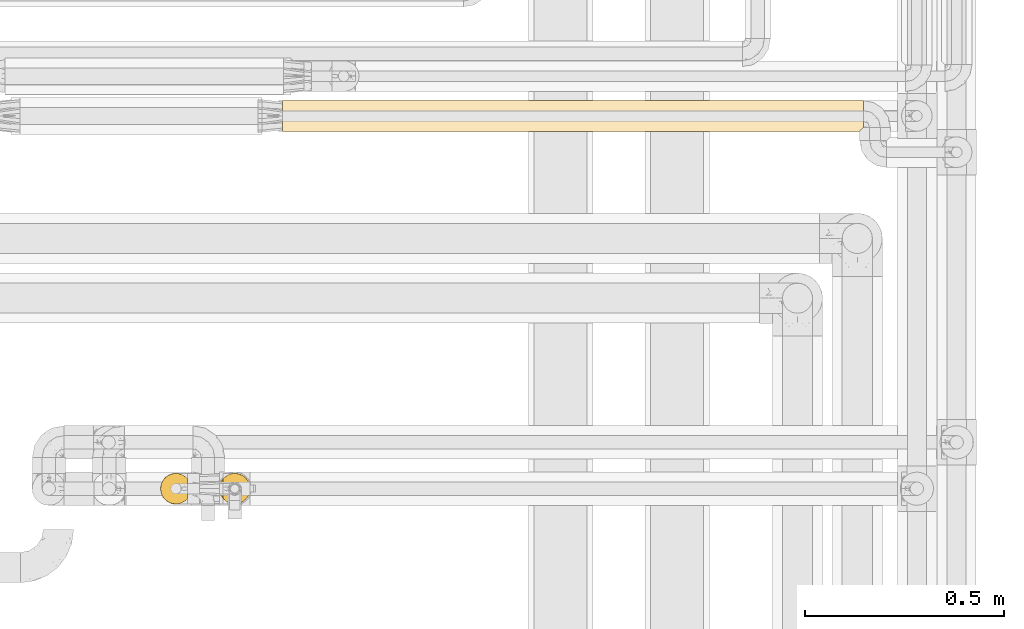
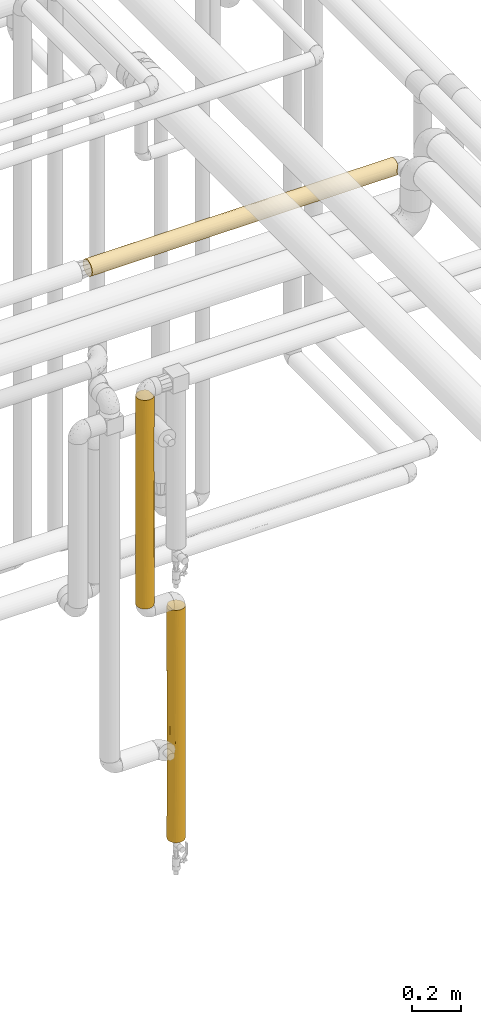
# One storey, part 48 of 827: 3 coverings.
"""IFC2X3 building model written with IfcOpenShell, lengths in millimetres."""

from ifc_helpers import new_model, entity, si_unit, converted_unit, derived_unit, direction, frame, origin, place, context, subcontext, project, spatial, faceted_brep, element, save


model = new_model("IFC2X3")

# Units and contexts
model_context = context("Model", 3, precision=0.01, world=origin(), true_north=direction((6.12303176911189e-17, 1.0)))
body_context = subcontext(model_context, "Body", "Model", "MODEL_VIEW")
ifc_project = project(units=[si_unit("LENGTHUNIT", "METRE", prefix="MILLI"), si_unit("AREAUNIT", "SQUARE_METRE"), si_unit("VOLUMEUNIT", "CUBIC_METRE"), converted_unit("PLANEANGLEUNIT", "DEGREE", entity("IfcRatioMeasure", 0.0174532925199433), si_unit("PLANEANGLEUNIT", "RADIAN"), dimensions=[0, 0, 0, 0, 0, 0, 0]), si_unit("MASSUNIT", "GRAM", prefix="KILO"), derived_unit("MASSDENSITYUNIT", [(si_unit("MASSUNIT", "GRAM", prefix="KILO"), 1), (si_unit("LENGTHUNIT", "METRE"), -3)]), derived_unit("MOMENTOFINERTIAUNIT", [(si_unit("LENGTHUNIT", "METRE"), 4)]), si_unit("TIMEUNIT", "SECOND"), si_unit("FREQUENCYUNIT", "HERTZ"), si_unit("THERMODYNAMICTEMPERATUREUNIT", "DEGREE_CELSIUS"), derived_unit("THERMALTRANSMITTANCEUNIT", [(si_unit("MASSUNIT", "GRAM", prefix="KILO"), 1), (si_unit("THERMODYNAMICTEMPERATUREUNIT", "KELVIN"), -1), (si_unit("TIMEUNIT", "SECOND"), -3)]), derived_unit("VOLUMETRICFLOWRATEUNIT", [(si_unit("LENGTHUNIT", "METRE"), 3), (si_unit("TIMEUNIT", "SECOND"), -1)]), derived_unit("MASSFLOWRATEUNIT", [(si_unit("MASSUNIT", "GRAM", prefix="KILO"), 1), (si_unit("TIMEUNIT", "SECOND"), -1)]), derived_unit("ROTATIONALFREQUENCYUNIT", [(si_unit("TIMEUNIT", "SECOND"), -1)]), si_unit("ELECTRICCURRENTUNIT", "AMPERE"), si_unit("ELECTRICVOLTAGEUNIT", "VOLT"), si_unit("POWERUNIT", "WATT"), si_unit("FORCEUNIT", "NEWTON", prefix="KILO"), si_unit("ILLUMINANCEUNIT", "LUX"), si_unit("LUMINOUSFLUXUNIT", "LUMEN"), si_unit("LUMINOUSINTENSITYUNIT", "CANDELA"), derived_unit("USERDEFINED", [(si_unit("MASSUNIT", "GRAM", prefix="KILO"), -1), (si_unit("LENGTHUNIT", "METRE"), -2), (si_unit("TIMEUNIT", "SECOND"), 3), (si_unit("LUMINOUSFLUXUNIT", "LUMEN"), 1)]), derived_unit("LINEARVELOCITYUNIT", [(si_unit("LENGTHUNIT", "METRE"), 1), (si_unit("TIMEUNIT", "SECOND"), -1)]), si_unit("PRESSUREUNIT", "PASCAL"), derived_unit("USERDEFINED", [(si_unit("LENGTHUNIT", "METRE"), -2), (si_unit("MASSUNIT", "GRAM", prefix="KILO"), 1), (si_unit("TIMEUNIT", "SECOND"), -2)]), derived_unit("LINEARFORCEUNIT", [(si_unit("MASSUNIT", "GRAM", prefix="KILO"), 1), (si_unit("LENGTHUNIT", "METRE"), 1), (si_unit("TIMEUNIT", "SECOND"), -2), (si_unit("LENGTHUNIT", "METRE"), -1)]), derived_unit("PLANARFORCEUNIT", [(si_unit("MASSUNIT", "GRAM", prefix="KILO"), 1), (si_unit("LENGTHUNIT", "METRE"), 1), (si_unit("TIMEUNIT", "SECOND"), -2), (si_unit("LENGTHUNIT", "METRE"), -2)])], contexts=[model_context])

# Site, building, storey
site_placement = place(None, origin())
site = spatial("IfcSite", under=ifc_project, at=site_placement, CompositionType="ELEMENT")
building_placement = place(site_placement, origin())
building = spatial("IfcBuilding", under=site, at=building_placement, CompositionType="ELEMENT")
storey_placement = place(building_placement, frame((0.0, 0.0, 28200.0)))
storey = spatial("IfcBuildingStorey", under=building, at=storey_placement, Name="08", CompositionType="ELEMENT", Elevation=28200.0)

# Coverings
covering_1_placement = place(storey_placement, frame((59152.64, 15404.21, 1620.55)))
element("IfcCovering", 1, at=covering_1_placement, inside=storey, Name=":ADSK_", ObjectType=":ADSK_", PredefinedType="INSULATION", context=body_context, shape_type="Brep", body=[
    faceted_brep([(6.74, 20.8, 1.6), (2.9, 30.06, 1.6), (1.6, 40.0, 1.6), (2.9, 49.93, 1.6), (6.74, 59.2, 1.6), (12.84, 67.15, 1.6), (20.8, 73.25, 1.6), (30.06, 77.09, 1.6), (40.0, 78.4, 1.6), (48.2, 77.51, 1.6), (56.01, 74.9, 1.6), (63.08, 70.68, 1.6), (69.1, 65.05, 1.6), (69.1, 14.94, 1.6), (63.08, 9.31, 1.6), (56.01, 5.09, 1.6), (48.2, 2.48, 1.6), (40.0, 1.6, 1.6), (30.06, 2.9, 1.6), (20.8, 6.74, 1.6), (12.84, 12.84, 1.6), (2.9, 49.93, 1050.35), (1.6, 40.0, 1050.35), (2.9, 30.06, 1050.35), (6.74, 20.8, 1050.35), (12.84, 12.84, 1050.35), (20.8, 6.74, 1050.35), (30.06, 2.9, 1050.35), (40.0, 1.6, 1050.35), (48.2, 2.48, 1050.35), (56.01, 5.09, 1050.35), (63.08, 9.31, 1050.35), (69.1, 14.94, 1050.35), (69.1, 65.05, 1050.35), (63.08, 70.68, 1050.35), (56.01, 74.9, 1050.35), (48.2, 77.51, 1050.35), (40.0, 78.4, 1050.35), (30.06, 77.09, 1050.35), (20.8, 73.25, 1050.35), (12.84, 67.15, 1050.35), (6.74, 59.2, 1050.35), (58.77, 73.49, 652.69), (61.61, 71.74, 843.36), (64.9, 69.22, 666.47), (77.79, 46.78, 10.29), (78.4, 40.0, 309.6), (78.4, 40.0, 227.27), (78.4, 40.0, 10.9), (78.4, 40.0, 824.67), (77.79, 46.78, 1041.65), (78.4, 40.0, 1041.05), (71.1, 62.51, 796.42), (70.99, 62.67, 525.97), (74.35, 57.15, 657.49), (74.52, 56.8, 443.66), (77.01, 50.2, 734.46), (71.1, 62.51, 255.52), (65.64, 68.57, 321.34), (52.17, 76.41, 268.66), (75.08, 55.6, 222.16), (73.07, 59.51, 5.57), (59.66, 72.98, 438.7), (59.66, 72.98, 203.98), (40.0, 78.4, 617.6), (52.17, 76.41, 709.86), (48.34, 77.48, 489.26), (73.07, 59.51, 1046.38), (76.0, 53.36, 1043.45), (74.63, 56.58, 863.26), (40.0, 78.4, 217.97), (40.0, 78.4, 833.97), (78.4, 40.0, 608.3), (77.01, 50.22, 375.06), (76.0, 53.36, 8.5), (40.0, 78.4, 309.6), (40.0, 78.4, 434.34), (78.4, 40.0, 443.64), (78.4, 40.0, 742.34), (75.08, 24.39, 829.78), (77.79, 33.21, 1041.65), (76.0, 26.63, 1043.45), (73.07, 20.48, 1046.38), (71.1, 17.48, 796.42), (77.79, 33.21, 10.29), (77.01, 29.79, 317.48), (76.0, 26.63, 8.5), (40.0, 1.6, 217.97), (40.0, 1.6, 833.97), (71.1, 17.48, 255.52), (74.35, 22.84, 394.45), (70.99, 17.32, 525.97), (74.52, 23.19, 608.28), (77.01, 29.77, 676.88), (52.17, 3.58, 709.86), (59.66, 7.01, 438.7), (52.89, 3.83, 489.26), (74.63, 23.41, 188.68), (65.64, 11.42, 321.34), (64.9, 10.77, 666.47), (73.07, 20.48, 5.57), (52.17, 3.58, 268.66), (59.3, 6.8, 822.07), (59.66, 7.01, 203.98), (40.0, 1.6, 742.34), (40.0, 1.6, 617.6), (40.0, 1.6, 434.34), (16.62, 9.53, 808.17), (25.3, 4.52, 728.14), (16.62, 9.53, 243.78), (9.53, 16.62, 294.56), (10.94, 14.89, 511.35), (4.52, 25.3, 445.84), (25.3, 4.52, 323.8), (22.95, 5.58, 525.97), (32.67, 2.3, 588.34), (32.96, 2.24, 326.15), (9.53, 16.62, 728.14), (2.81, 30.42, 250.87), (2.28, 32.79, 725.79), (1.6, 40.0, 617.6), (2.22, 33.1, 487.54), (32.41, 2.35, 822.47), (5.54, 23.05, 229.27), (16.62, 9.53, 525.97), (1.6, 40.0, 833.97), (1.6, 40.0, 742.35), (4.52, 25.3, 791.56), (1.6, 40.0, 434.34), (1.6, 40.0, 309.6), (1.6, 40.0, 217.97), (9.53, 63.37, 808.17), (4.52, 54.69, 728.14), (9.53, 63.37, 243.78), (16.62, 70.46, 294.56), (14.89, 69.06, 511.35), (25.3, 75.47, 445.84), (4.52, 54.69, 323.8), (5.58, 57.04, 525.97), (2.3, 47.32, 588.34), (2.24, 47.03, 326.15), (16.62, 70.46, 728.14), (30.42, 77.18, 250.87), (32.79, 77.71, 725.79), (33.1, 77.77, 487.54), (2.35, 47.58, 822.47), (23.05, 74.45, 229.27), (9.53, 63.37, 525.97), (25.3, 75.47, 791.56)], [[[0, 1, 2, 3, 4, 5, 6, 7, 8, 9, 10, 11, 12, 13, 14, 15, 16, 17, 18, 19, 20]], [[21, 22, 23, 24, 25, 26, 27, 28, 29, 30, 31, 32, 33, 34, 35, 36, 37, 38, 39, 40, 41]], [[42, 43, 44]], [[45, 46, 47, 48]], [[49, 50, 51]], [[44, 52, 53]], [[52, 54, 53]], [[55, 54, 56]], [[57, 58, 53]], [[10, 9, 59]], [[60, 61, 57]], [[62, 63, 59]], [[64, 65, 66]], [[67, 68, 69]], [[62, 59, 66]], [[63, 11, 10]], [[59, 63, 10]], [[43, 52, 44]], [[9, 70, 59]], [[54, 69, 56]], [[65, 71, 36]], [[70, 9, 8]], [[71, 37, 36]], [[58, 11, 63]], [[72, 73, 56]], [[50, 49, 56]], [[35, 34, 43]], [[73, 60, 55]], [[74, 60, 45]], [[56, 68, 50]], [[12, 11, 58]], [[61, 12, 57]], [[73, 46, 45]], [[65, 36, 35]], [[55, 53, 54]], [[67, 52, 33]], [[64, 66, 70, 75, 76]], [[58, 44, 53]], [[59, 70, 66]], [[42, 44, 62]], [[43, 33, 52]], [[71, 65, 64]], [[58, 63, 62]], [[58, 62, 44]], [[58, 57, 12]], [[52, 67, 69]], [[55, 56, 73]], [[56, 69, 68]], [[52, 69, 54]], [[73, 45, 60]], [[57, 53, 55]], [[61, 60, 74]], [[57, 55, 60]], [[73, 72, 77, 46]], [[56, 49, 78, 72]], [[66, 65, 42]], [[66, 42, 62]], [[43, 65, 35]], [[43, 42, 65]], [[33, 43, 34]], [[79, 80, 81]], [[82, 32, 83]], [[84, 85, 86]], [[87, 17, 16]], [[29, 28, 88]], [[89, 90, 91]], [[80, 78, 49, 51]], [[47, 84, 48]], [[79, 92, 93]], [[78, 80, 93]], [[29, 94, 30]], [[95, 94, 96]], [[90, 97, 85]], [[98, 99, 95]], [[84, 47, 85]], [[83, 99, 91]], [[89, 13, 100]], [[96, 101, 95]], [[79, 82, 83]], [[91, 99, 98]], [[95, 99, 102]], [[15, 103, 101]], [[100, 86, 97]], [[101, 16, 15]], [[103, 98, 95]], [[102, 30, 94]], [[94, 88, 104, 105]], [[89, 98, 13]], [[94, 29, 88]], [[92, 90, 85]], [[14, 103, 15]], [[77, 93, 85]], [[105, 106, 96]], [[99, 32, 31]], [[92, 91, 90]], [[101, 87, 16]], [[96, 106, 101]], [[32, 99, 83]], [[31, 30, 102]], [[14, 13, 98]], [[101, 103, 95]], [[14, 98, 103]], [[91, 98, 89]], [[89, 100, 97]], [[92, 85, 93]], [[85, 97, 86]], [[89, 97, 90]], [[93, 80, 79]], [[83, 91, 92]], [[82, 79, 81]], [[83, 92, 79]], [[93, 77, 72, 78]], [[85, 47, 46, 77]], [[96, 94, 105]], [[101, 106, 87]], [[95, 102, 94]], [[31, 102, 99]], [[107, 108, 26]], [[109, 110, 20]], [[111, 112, 110]], [[113, 114, 109]], [[26, 108, 27]], [[106, 115, 116]], [[25, 107, 26]], [[106, 116, 87]], [[109, 20, 19]], [[19, 18, 113]], [[24, 117, 25]], [[1, 118, 2]], [[119, 120, 121]], [[114, 108, 107]], [[115, 122, 108]], [[112, 123, 110]], [[118, 123, 112]], [[110, 0, 20]], [[124, 107, 117]], [[119, 125, 126, 120]], [[121, 118, 112]], [[127, 117, 24]], [[18, 87, 116]], [[113, 116, 115]], [[127, 24, 23]], [[119, 121, 112]], [[117, 111, 124]], [[125, 119, 23]], [[27, 122, 28]], [[112, 117, 127]], [[113, 109, 19]], [[109, 124, 111]], [[117, 107, 25]], [[107, 124, 109, 114]], [[18, 17, 87]], [[115, 106, 105, 104]], [[18, 116, 113]], [[122, 115, 104]], [[115, 108, 114]], [[23, 22, 125]], [[112, 127, 119]], [[23, 119, 127]], [[121, 120, 128, 129]], [[118, 129, 130, 2]], [[129, 118, 121]], [[123, 1, 0]], [[1, 123, 118]], [[0, 110, 123]], [[122, 104, 88, 28]], [[27, 108, 122]], [[115, 114, 113]], [[112, 111, 117]], [[109, 111, 110]], [[131, 132, 41]], [[133, 134, 5]], [[135, 136, 134]], [[137, 138, 133]], [[41, 132, 21]], [[128, 139, 140]], [[40, 131, 41]], [[140, 130, 129, 128]], [[133, 5, 4]], [[4, 3, 137]], [[39, 141, 40]], [[7, 142, 8]], [[143, 64, 144]], [[138, 132, 131]], [[139, 145, 132]], [[136, 146, 134]], [[142, 146, 136]], [[134, 6, 5]], [[147, 131, 141]], [[64, 143, 71]], [[144, 142, 136]], [[148, 141, 39]], [[3, 130, 140]], [[137, 140, 139]], [[148, 39, 38]], [[143, 144, 136]], [[141, 135, 147]], [[71, 143, 38]], [[21, 145, 22]], [[136, 141, 148]], [[137, 133, 4]], [[133, 147, 135]], [[141, 131, 40]], [[131, 147, 133, 138]], [[3, 2, 130]], [[139, 128, 120, 126]], [[3, 140, 137]], [[145, 139, 126]], [[139, 132, 138]], [[38, 37, 71]], [[136, 148, 143]], [[38, 143, 148]], [[144, 64, 76, 75]], [[142, 75, 70, 8]], [[75, 142, 144]], [[146, 7, 6]], [[7, 146, 142]], [[6, 134, 146]], [[145, 126, 125, 22]], [[21, 132, 145]], [[139, 138, 137]], [[136, 135, 141]], [[133, 135, 134]], [[12, 61, 74, 45, 48, 84, 86, 100, 13]], [[32, 82, 81, 80, 51, 50, 68, 67, 33]]]),
])
covering_2_placement = place(storey_placement, frame((59300.47, 15404.21, 395.55)))
element("IfcCovering", 2, at=covering_2_placement, inside=storey, Name=":ADSK_", ObjectType=":ADSK_", PredefinedType="INSULATION", context=body_context, shape_type="Brep", body=[
    faceted_brep([(73.25, 20.8, 1168.4), (77.09, 30.06, 1168.4), (78.4, 40.0, 1168.4), (77.09, 49.93, 1168.4), (73.25, 59.2, 1168.4), (67.15, 67.15, 1168.4), (59.2, 73.25, 1168.4), (49.93, 77.09, 1168.4), (40.0, 78.4, 1168.4), (31.79, 77.51, 1168.4), (23.98, 74.9, 1168.4), (16.91, 70.68, 1168.4), (10.9, 65.05, 1168.4), (10.9, 14.94, 1168.4), (16.91, 9.31, 1168.4), (23.98, 5.09, 1168.4), (31.79, 2.48, 1168.4), (40.0, 1.6, 1168.4), (49.93, 2.9, 1168.4), (59.2, 6.74, 1168.4), (67.15, 12.84, 1168.4), (73.25, 20.8, 0.0), (67.15, 12.84, 0.0), (59.2, 6.74, 0.0), (49.93, 2.9, 0.0), (40.0, 1.6, 0.0), (30.06, 2.9, 0.0), (20.8, 6.74, 0.0), (12.84, 12.84, 0.0), (6.74, 20.8, 0.0), (2.9, 30.06, 0.0), (1.6, 40.0, 0.0), (2.9, 49.93, 0.0), (6.74, 59.2, 0.0), (12.84, 67.15, 0.0), (20.8, 73.25, 0.0), (30.06, 77.09, 0.0), (40.0, 78.4, 0.0), (49.93, 77.09, 0.0), (59.2, 73.25, 0.0), (67.15, 67.15, 0.0), (73.25, 59.2, 0.0), (77.09, 49.93, 0.0), (78.4, 40.0, 0.0), (77.09, 30.06, 0.0), (70.46, 16.62, 345.97), (63.37, 9.53, 263.96), (63.37, 9.53, 912.5), (63.37, 9.53, 584.2), (70.46, 16.62, 862.14), (57.04, 5.59, 249.94), (50.49, 3.06, 324.56), (40.0, 1.6, 216.37), (77.7, 32.7, 721.86), (78.4, 40.0, 800.57), (77.81, 33.34, 946.82), (57.02, 5.58, 465.73), (40.0, 1.6, 432.75), (50.18, 2.97, 592.39), (40.0, 1.6, 952.03), (75.47, 25.3, 263.96), (77.11, 30.16, 475.22), (75.47, 25.3, 686.49), (47.05, 2.25, 843.84), (40.0, 1.6, 735.65), (75.47, 25.3, 949.21), (54.69, 4.52, 822.43), (70.22, 16.31, 604.05), (74.36, 22.87, 475.22), (77.68, 32.6, 267.21), (78.4, 40.0, 432.75), (78.4, 40.0, 952.03), (78.4, 40.0, 735.65), (78.4, 40.0, 216.37), (77.74, 47.05, 843.84), (74.69, 56.46, 573.54), (75.47, 54.69, 822.43), (77.37, 48.81, 584.2), (77.74, 47.05, 324.56), (75.47, 54.69, 345.97), (47.39, 77.68, 267.21), (40.0, 78.4, 432.75), (49.83, 77.11, 475.22), (70.46, 63.37, 912.5), (70.46, 63.37, 584.2), (63.37, 70.46, 862.14), (70.46, 63.37, 263.96), (63.37, 70.46, 345.97), (47.29, 77.7, 721.86), (40.0, 78.4, 800.57), (46.65, 77.81, 946.82), (54.69, 75.47, 686.49), (54.69, 75.47, 949.21), (54.69, 75.47, 263.96), (63.68, 70.22, 604.05), (57.12, 74.36, 475.22), (40.0, 78.4, 952.03), (40.0, 78.4, 735.65), (40.0, 78.4, 216.37), (16.62, 70.46, 268.22), (25.3, 75.47, 363.06), (13.75, 68.03, 896.73), (20.33, 72.98, 719.55), (14.05, 68.31, 664.4), (5.39, 56.65, 844.73), (9.23, 62.98, 799.35), (9.03, 62.7, 581.17), (18.44, 71.77, 493.87), (27.82, 76.41, 896.74), (31.49, 77.44, 584.2), (32.9, 77.73, 324.56), (20.33, 72.98, 959.72), (9.53, 63.37, 251.45), (2.2, 46.78, 1159.7), (4.0, 53.36, 1161.5), (2.47, 48.14, 834.54), (4.52, 54.69, 333.2), (3.79, 52.79, 599.79), (1.6, 40.0, 942.73), (1.6, 40.0, 726.35), (1.6, 40.0, 432.74), (6.92, 59.51, 1164.43), (1.6, 40.0, 1159.1), (2.25, 47.03, 324.56), (1.6, 40.0, 216.37), (4.52, 25.3, 333.2), (6.92, 20.48, 1164.43), (8.81, 17.59, 961.78), (5.39, 23.34, 844.73), (2.47, 31.85, 834.54), (3.79, 27.2, 599.79), (18.44, 8.22, 493.87), (14.05, 11.69, 664.4), (9.03, 17.29, 581.17), (25.3, 4.52, 363.06), (32.9, 2.26, 324.56), (30.37, 2.82, 579.18), (13.75, 11.96, 896.73), (2.25, 32.96, 324.56), (16.62, 9.53, 268.22), (4.0, 26.63, 1161.5), (9.53, 16.62, 251.45), (2.2, 33.21, 1159.7), (29.69, 3.0, 843.84), (20.33, 7.01, 959.72), (20.33, 7.01, 719.55)], [[[0, 1, 2, 3, 4, 5, 6, 7, 8, 9, 10, 11, 12, 13, 14, 15, 16, 17, 18, 19, 20]], [[21, 22, 23, 24, 25, 26, 27, 28, 29, 30, 31, 32, 33, 34, 35, 36, 37, 38, 39, 40, 41, 42, 43, 44]], [[45, 46, 22]], [[47, 48, 49]], [[50, 24, 23]], [[51, 52, 24]], [[22, 21, 45]], [[53, 54, 55]], [[56, 50, 46]], [[51, 57, 52]], [[51, 58, 57]], [[18, 17, 59]], [[52, 25, 24]], [[45, 21, 60]], [[23, 22, 46]], [[61, 53, 62]], [[49, 0, 20]], [[63, 59, 64]], [[1, 0, 65]], [[47, 49, 20]], [[66, 19, 18]], [[60, 21, 44]], [[49, 62, 65]], [[55, 1, 65]], [[66, 58, 56]], [[62, 67, 68]], [[69, 70, 61]], [[66, 63, 58]], [[20, 19, 47]], [[1, 55, 2]], [[68, 67, 45]], [[45, 48, 46]], [[46, 48, 56]], [[69, 61, 60]], [[68, 60, 61]], [[19, 66, 47]], [[48, 47, 66]], [[49, 65, 0]], [[53, 55, 65]], [[53, 65, 62]], [[55, 54, 71, 2]], [[62, 68, 61]], [[53, 70, 72, 54]], [[69, 44, 43]], [[70, 53, 61]], [[43, 73, 70, 69]], [[64, 57, 58]], [[59, 63, 18]], [[18, 63, 66]], [[58, 63, 64]], [[56, 58, 51]], [[56, 51, 50]], [[66, 56, 48]], [[67, 62, 49]], [[45, 60, 68]], [[49, 48, 67]], [[48, 45, 67]], [[24, 50, 51]], [[23, 46, 50]], [[44, 69, 60]], [[3, 71, 74]], [[42, 73, 43]], [[3, 2, 71]], [[75, 76, 77]], [[4, 3, 76]], [[78, 70, 73]], [[74, 71, 54, 72]], [[79, 42, 41]], [[80, 81, 82]], [[83, 84, 85]], [[84, 86, 87]], [[88, 89, 90]], [[87, 40, 39]], [[5, 4, 83]], [[82, 88, 91]], [[77, 72, 70]], [[77, 74, 72]], [[7, 6, 92]], [[83, 85, 5]], [[87, 39, 93]], [[84, 75, 86]], [[85, 91, 92]], [[90, 7, 92]], [[85, 6, 5]], [[86, 41, 40]], [[93, 39, 38]], [[91, 94, 95]], [[41, 86, 79]], [[7, 90, 8]], [[95, 94, 87]], [[80, 82, 93]], [[95, 93, 82]], [[40, 87, 86]], [[4, 76, 83]], [[84, 83, 76]], [[77, 70, 78]], [[75, 77, 79]], [[85, 92, 6]], [[88, 90, 92]], [[88, 92, 91]], [[90, 89, 96, 8]], [[91, 95, 82]], [[88, 81, 97, 89]], [[80, 38, 37]], [[81, 88, 82]], [[37, 98, 81, 80]], [[77, 76, 74]], [[3, 74, 76]], [[78, 42, 79]], [[42, 78, 73]], [[77, 78, 79]], [[94, 91, 85]], [[87, 93, 95]], [[85, 84, 94]], [[84, 87, 94]], [[38, 80, 93]], [[86, 75, 79]], [[76, 75, 84]], [[99, 100, 35]], [[12, 11, 101]], [[102, 103, 101]], [[104, 105, 106]], [[99, 106, 107]], [[102, 108, 109]], [[100, 36, 35]], [[98, 110, 81]], [[102, 111, 108]], [[108, 10, 9]], [[109, 108, 97]], [[111, 11, 10]], [[109, 97, 81]], [[11, 111, 101]], [[81, 110, 109]], [[112, 106, 99]], [[113, 114, 115]], [[116, 117, 106]], [[113, 115, 118]], [[119, 117, 120]], [[105, 121, 12]], [[101, 105, 12]], [[114, 121, 104]], [[34, 99, 35]], [[99, 34, 112]], [[118, 122, 113]], [[116, 33, 32]], [[36, 98, 37]], [[120, 123, 124]], [[32, 124, 123]], [[119, 115, 117]], [[115, 114, 104]], [[119, 118, 115]], [[117, 115, 104]], [[34, 33, 112]], [[106, 103, 107]], [[106, 117, 104]], [[117, 123, 120]], [[108, 111, 10]], [[101, 111, 102]], [[33, 116, 112]], [[106, 112, 116]], [[102, 109, 100]], [[9, 96, 108]], [[32, 31, 124]], [[117, 116, 123]], [[32, 123, 116]], [[110, 36, 100]], [[36, 110, 98]], [[109, 110, 100]], [[103, 102, 107]], [[105, 103, 106]], [[102, 100, 107]], [[100, 99, 107]], [[121, 105, 104]], [[103, 105, 101]], [[96, 9, 8]], [[108, 96, 89, 97]], [[125, 30, 29]], [[13, 126, 127]], [[128, 129, 130]], [[131, 132, 133]], [[134, 135, 136]], [[133, 137, 127]], [[120, 124, 138]], [[119, 129, 118]], [[134, 139, 27]], [[126, 140, 128]], [[29, 28, 141]], [[118, 129, 142]], [[126, 128, 127]], [[14, 13, 137]], [[57, 135, 52]], [[139, 141, 28]], [[136, 64, 143]], [[59, 143, 64]], [[15, 143, 16]], [[28, 27, 139]], [[59, 17, 16]], [[26, 134, 27]], [[120, 138, 130]], [[144, 15, 14]], [[26, 52, 135]], [[140, 142, 129]], [[15, 144, 143]], [[145, 144, 137]], [[131, 136, 145]], [[59, 16, 143]], [[132, 145, 137]], [[130, 133, 128]], [[30, 124, 31]], [[142, 122, 118]], [[119, 120, 130]], [[129, 128, 140]], [[132, 131, 145]], [[141, 133, 125]], [[130, 129, 119]], [[133, 130, 125]], [[137, 144, 14]], [[143, 144, 145]], [[133, 141, 139]], [[125, 29, 141]], [[138, 30, 125]], [[30, 138, 124]], [[130, 138, 125]], [[26, 25, 52]], [[57, 64, 136]], [[26, 135, 134]], [[136, 135, 57]], [[145, 136, 143]], [[133, 127, 128]], [[13, 127, 137]], [[137, 133, 132]], [[131, 133, 139]], [[139, 134, 131]], [[136, 131, 134]], [[142, 140, 126, 13, 12, 121, 114, 113, 122]]]),
])
covering_3_placement = place(storey_placement, frame((59460.44, 16339.84, 2610.0)))
element("IfcCovering", 3, at=covering_3_placement, inside=storey, Name=":ADSK_", ObjectType=":ADSK_", PredefinedType="INSULATION", context=body_context, shape_type="Brep", body=[
    faceted_brep([(1458.1, 59.2, 6.74), (1458.1, 67.15, 12.84), (1458.1, 73.25, 20.8), (1458.1, 77.09, 30.06), (1458.1, 78.4, 40.0), (1458.1, 77.09, 49.93), (1458.1, 73.25, 59.2), (1458.1, 67.15, 67.15), (1458.1, 59.2, 73.25), (1458.1, 49.93, 77.09), (1458.1, 40.0, 78.4), (1458.1, 31.79, 77.51), (1458.1, 23.98, 74.9), (1458.1, 16.91, 70.68), (1458.1, 10.9, 65.05), (1458.1, 10.9, 14.94), (1458.1, 16.91, 9.31), (1458.1, 23.98, 5.09), (1458.1, 31.79, 2.48), (1458.1, 40.0, 1.6), (1458.1, 49.93, 2.9), (0.0, 59.2, 6.74), (0.0, 49.93, 2.9), (0.0, 40.0, 1.6), (0.0, 30.06, 2.9), (0.0, 20.8, 6.74), (0.0, 12.84, 12.84), (0.0, 6.74, 20.8), (0.0, 2.9, 30.06), (0.0, 1.6, 40.0), (0.0, 2.9, 49.93), (0.0, 6.74, 59.2), (0.0, 12.84, 67.15), (0.0, 20.8, 73.25), (0.0, 30.06, 77.09), (0.0, 40.0, 78.4), (0.0, 49.93, 77.09), (0.0, 59.2, 73.25), (0.0, 67.15, 67.15), (0.0, 73.25, 59.2), (0.0, 77.09, 49.93), (0.0, 78.4, 40.0), (0.0, 77.09, 30.06), (0.0, 73.25, 20.8), (0.0, 67.15, 12.84), (1451.2, 4.0, 26.63), (1449.41, 2.2, 33.21), (1124.24, 2.49, 31.75), (290.83, 16.62, 9.53), (253.63, 9.53, 16.62), (437.48, 2.18, 33.3), (583.31, 1.6, 40.0), (291.66, 1.6, 40.0), (1172.46, 13.75, 11.96), (229.0, 2.89, 30.09), (201.09, 5.48, 23.16), (405.54, 4.52, 25.3), (1265.64, 8.86, 17.51), (1074.71, 5.41, 23.31), (1052.84, 9.41, 16.78), (296.31, 40.0, 1.6), (316.47, 31.94, 2.45), (1232.43, 1.6, 40.0), (195.01, 25.3, 4.52), (1016.06, 1.6, 40.0), (497.44, 9.01, 17.31), (771.63, 3.05, 29.53), (1172.46, 27.82, 3.58), (1241.73, 40.0, 1.6), (437.93, 25.3, 4.52), (915.56, 13.43, 12.26), (974.52, 20.33, 7.01), (1241.04, 20.33, 7.01), (742.51, 9.08, 17.22), (630.6, 16.89, 9.33), (842.88, 30.25, 2.85), (1025.36, 40.0, 1.6), (632.69, 5.37, 23.39), (853.57, 5.62, 22.88), (1454.13, 6.92, 20.48), (549.99, 32.08, 2.42), (1448.8, 1.6, 40.0), (799.68, 1.6, 40.0), (665.08, 25.59, 4.4), (808.98, 40.0, 1.6), (592.61, 40.0, 1.6), (259.19, 63.37, 9.53), (324.27, 70.46, 16.62), (1052.78, 54.69, 4.52), (1133.54, 47.28, 2.29), (836.45, 47.92, 2.42), (240.27, 57.7, 5.92), (602.93, 49.94, 2.91), (390.47, 47.15, 2.27), (410.07, 54.69, 4.52), (216.37, 78.4, 40.0), (546.76, 60.05, 7.25), (760.83, 55.88, 5.04), (774.95, 76.51, 28.12), (961.25, 77.7, 32.73), (1020.17, 75.47, 25.3), (1204.47, 63.37, 9.53), (1167.27, 70.46, 16.62), (566.77, 71.4, 17.9), (496.82, 65.99, 11.74), (245.05, 75.47, 25.3), (324.56, 77.7, 32.71), (529.72, 75.47, 25.3), (969.46, 61.64, 8.28), (842.37, 70.82, 17.1), (561.65, 77.77, 33.12), (1243.49, 74.63, 23.42), (1207.22, 77.29, 30.87), (1263.45, 53.07, 3.89), (213.87, 51.51, 3.36), (734.44, 63.37, 9.53), (296.31, 78.4, 40.0), (432.75, 78.4, 40.0), (649.12, 78.4, 40.0), (808.98, 78.4, 40.0), (865.49, 78.4, 40.0), (592.61, 78.4, 40.0), (1025.36, 78.4, 40.0), (1161.8, 78.4, 40.0), (1241.73, 78.4, 40.0), (259.19, 70.46, 63.37), (324.27, 63.37, 70.46), (1052.78, 75.47, 54.69), (1133.54, 77.7, 47.28), (836.45, 77.57, 47.92), (240.27, 74.07, 57.7), (602.93, 77.08, 49.94), (390.47, 77.72, 47.15), (410.07, 75.47, 54.69), (216.37, 40.0, 78.4), (546.76, 72.74, 60.05), (760.83, 74.95, 55.88), (774.95, 51.88, 76.51), (961.25, 47.26, 77.7), (1020.17, 54.69, 75.47), (1204.47, 70.46, 63.37), (1167.27, 63.37, 70.46), (566.77, 62.09, 71.4), (496.82, 68.25, 65.99), (245.05, 54.69, 75.47), (324.56, 47.28, 77.7), (529.72, 54.69, 75.47), (969.46, 71.71, 61.64), (842.37, 62.89, 70.82), (561.65, 46.88, 77.77), (1243.49, 56.57, 74.63), (1207.22, 49.13, 77.29), (1263.45, 76.1, 53.07), (213.87, 76.63, 51.51), (734.44, 70.46, 63.37), (296.31, 40.0, 78.4), (432.75, 40.0, 78.4), (649.12, 40.0, 78.4), (808.98, 40.0, 78.4), (865.49, 40.0, 78.4), (592.61, 40.0, 78.4), (1025.36, 40.0, 78.4), (1161.8, 40.0, 78.4), (1241.73, 40.0, 78.4), (1172.46, 27.82, 76.41), (1124.24, 2.49, 48.24), (1451.2, 4.0, 53.36), (1074.71, 5.41, 56.68), (1052.84, 9.41, 63.21), (1172.46, 13.75, 68.03), (915.56, 13.43, 67.73), (437.48, 2.18, 46.69), (229.0, 2.89, 49.9), (771.63, 3.05, 50.46), (437.93, 25.3, 75.47), (195.01, 25.3, 75.47), (290.83, 16.62, 70.46), (316.47, 31.94, 77.54), (549.99, 32.08, 77.57), (630.6, 16.89, 70.66), (974.52, 20.33, 72.98), (1241.04, 20.33, 72.98), (853.64, 5.62, 57.11), (623.94, 5.54, 56.95), (1449.41, 2.2, 46.78), (1265.64, 8.86, 62.48), (201.09, 5.48, 56.83), (1454.13, 6.92, 59.51), (253.63, 9.53, 63.37), (842.88, 30.25, 77.14), (405.54, 4.52, 54.69), (498.17, 9.35, 63.14), (665.08, 25.59, 75.59), (742.51, 9.08, 62.77)], [[[0, 1, 2, 3, 4, 5, 6, 7, 8, 9, 10, 11, 12, 13, 14, 15, 16, 17, 18, 19, 20]], [[21, 22, 23, 24, 25, 26, 27, 28, 29, 30, 31, 32, 33, 34, 35, 36, 37, 38, 39, 40, 41, 42, 43, 44]], [[45, 46, 47]], [[26, 48, 49]], [[50, 51, 52]], [[15, 53, 16]], [[54, 55, 56]], [[57, 58, 59]], [[60, 61, 23]], [[45, 58, 57]], [[25, 48, 26]], [[62, 47, 46]], [[27, 26, 49]], [[63, 48, 25]], [[47, 62, 64]], [[65, 56, 49]], [[66, 58, 47]], [[67, 68, 18]], [[61, 69, 63]], [[17, 67, 18]], [[53, 70, 71]], [[16, 53, 72]], [[73, 65, 74]], [[72, 17, 16]], [[54, 56, 50]], [[24, 63, 25]], [[75, 76, 67]], [[77, 78, 66]], [[57, 15, 79]], [[71, 67, 72]], [[59, 73, 70]], [[69, 61, 80]], [[75, 67, 71]], [[18, 68, 19]], [[46, 81, 62]], [[66, 64, 82, 51]], [[47, 58, 45]], [[50, 66, 51]], [[66, 50, 77]], [[74, 48, 69]], [[60, 80, 61]], [[73, 77, 65]], [[71, 74, 83]], [[28, 54, 29]], [[80, 84, 75]], [[83, 69, 80]], [[70, 74, 71]], [[48, 74, 65]], [[76, 68, 67]], [[55, 49, 56]], [[24, 23, 61]], [[48, 63, 69]], [[24, 61, 63]], [[80, 60, 85, 84]], [[83, 80, 75]], [[71, 83, 75]], [[74, 69, 83]], [[59, 70, 53]], [[74, 70, 73]], [[53, 15, 57]], [[59, 58, 78]], [[57, 79, 45]], [[53, 57, 59]], [[52, 29, 54]], [[50, 56, 77]], [[52, 54, 50]], [[55, 28, 27]], [[28, 55, 54]], [[49, 55, 27]], [[71, 72, 53]], [[17, 72, 67]], [[64, 66, 47]], [[78, 77, 73]], [[56, 65, 77]], [[65, 49, 48]], [[59, 78, 73]], [[58, 66, 78]], [[84, 76, 75]], [[86, 44, 87]], [[88, 89, 90]], [[20, 68, 89]], [[21, 44, 86]], [[86, 91, 21]], [[92, 93, 94]], [[42, 41, 95]], [[92, 96, 97]], [[97, 88, 90]], [[98, 99, 100]], [[101, 102, 1]], [[87, 103, 104]], [[105, 106, 107]], [[102, 108, 109]], [[110, 98, 107]], [[111, 100, 112]], [[113, 20, 89]], [[43, 42, 105]], [[43, 87, 44]], [[100, 102, 109]], [[102, 100, 111]], [[99, 112, 100]], [[2, 1, 102]], [[76, 89, 68]], [[114, 94, 93]], [[105, 87, 43]], [[107, 106, 110]], [[96, 86, 104]], [[1, 0, 101]], [[3, 112, 4]], [[101, 108, 102]], [[104, 86, 87]], [[22, 114, 23]], [[114, 91, 94]], [[113, 101, 0]], [[108, 101, 88]], [[115, 104, 103]], [[109, 103, 98]], [[95, 106, 42]], [[87, 105, 107]], [[106, 95, 116, 117]], [[106, 117, 110]], [[42, 106, 105]], [[98, 118, 119, 120]], [[120, 99, 98]], [[110, 118, 98]], [[109, 98, 100]], [[110, 117, 121, 118]], [[20, 19, 68]], [[90, 89, 76]], [[89, 88, 113]], [[90, 76, 84, 85]], [[92, 94, 96]], [[101, 113, 88]], [[0, 20, 113]], [[99, 120, 122, 123]], [[112, 123, 124, 4]], [[123, 112, 99]], [[111, 3, 2]], [[3, 111, 112]], [[102, 111, 2]], [[87, 107, 103]], [[96, 104, 115]], [[98, 103, 107]], [[115, 103, 109]], [[97, 96, 115]], [[96, 94, 91]], [[97, 115, 108]], [[97, 90, 92]], [[90, 85, 92]], [[93, 85, 60]], [[85, 93, 92]], [[60, 23, 114]], [[60, 114, 93]], [[21, 114, 22]], [[21, 91, 114]], [[96, 91, 86]], [[97, 108, 88]], [[109, 108, 115]], [[125, 38, 126]], [[127, 128, 129]], [[5, 124, 128]], [[39, 38, 125]], [[125, 130, 39]], [[131, 132, 133]], [[36, 35, 134]], [[131, 135, 136]], [[136, 127, 129]], [[137, 138, 139]], [[140, 141, 7]], [[126, 142, 143]], [[144, 145, 146]], [[141, 147, 148]], [[149, 137, 146]], [[150, 139, 151]], [[152, 5, 128]], [[37, 36, 144]], [[37, 126, 38]], [[139, 141, 148]], [[141, 139, 150]], [[138, 151, 139]], [[8, 7, 141]], [[128, 124, 123, 122]], [[153, 133, 132]], [[144, 126, 37]], [[146, 145, 149]], [[135, 125, 143]], [[7, 6, 140]], [[9, 151, 10]], [[140, 147, 141]], [[143, 125, 126]], [[40, 153, 41]], [[153, 130, 133]], [[152, 140, 6]], [[147, 140, 127]], [[154, 143, 142]], [[148, 142, 137]], [[134, 145, 36]], [[126, 144, 146]], [[145, 134, 155, 156]], [[145, 156, 149]], [[36, 145, 144]], [[137, 157, 158, 159]], [[159, 138, 137]], [[149, 157, 137]], [[148, 137, 139]], [[149, 156, 160, 157]], [[5, 4, 124]], [[129, 128, 122]], [[128, 127, 152]], [[129, 122, 120, 119, 118, 121]], [[131, 133, 135]], [[140, 152, 127]], [[6, 5, 152]], [[138, 159, 161, 162]], [[151, 162, 163, 10]], [[162, 151, 138]], [[150, 9, 8]], [[9, 150, 151]], [[141, 150, 8]], [[126, 146, 142]], [[135, 143, 154]], [[137, 142, 146]], [[154, 142, 148]], [[136, 135, 154]], [[135, 133, 130]], [[136, 154, 147]], [[136, 129, 131]], [[129, 121, 131]], [[132, 121, 117, 116]], [[121, 132, 131]], [[153, 116, 95, 41]], [[116, 153, 132]], [[39, 153, 40]], [[39, 130, 153]], [[135, 130, 125]], [[136, 147, 127]], [[148, 147, 154]], [[164, 163, 162, 161]], [[165, 166, 167]], [[168, 169, 170]], [[171, 172, 52]], [[64, 173, 51, 82]], [[174, 175, 176]], [[33, 175, 34]], [[155, 177, 178]], [[176, 179, 174]], [[170, 169, 180]], [[34, 175, 177]], [[180, 169, 181]], [[169, 13, 181]], [[64, 62, 165]], [[164, 181, 12]], [[33, 32, 176]], [[173, 182, 183]], [[184, 166, 165]], [[62, 81, 184]], [[168, 185, 169]], [[52, 172, 29]], [[172, 186, 30]], [[165, 173, 64]], [[13, 169, 14]], [[185, 166, 187]], [[176, 32, 188]], [[180, 164, 189]], [[188, 190, 191]], [[192, 189, 178]], [[164, 12, 11]], [[185, 187, 14]], [[164, 11, 163]], [[189, 164, 161]], [[184, 165, 62]], [[165, 167, 173]], [[182, 173, 167]], [[173, 183, 171]], [[32, 31, 188]], [[34, 177, 35]], [[188, 191, 176]], [[178, 158, 157, 160, 156, 155]], [[51, 171, 52]], [[170, 179, 193]], [[192, 180, 189]], [[11, 10, 163]], [[186, 188, 31]], [[190, 183, 191]], [[176, 175, 33]], [[177, 175, 174]], [[177, 174, 178]], [[177, 155, 134, 35]], [[192, 178, 174]], [[178, 189, 158]], [[174, 179, 192]], [[180, 192, 179]], [[179, 170, 180]], [[193, 182, 168]], [[193, 168, 170]], [[167, 166, 185]], [[169, 185, 14]], [[167, 185, 168]], [[173, 171, 51]], [[172, 171, 190]], [[186, 172, 190]], [[172, 30, 29]], [[188, 186, 190]], [[30, 186, 31]], [[12, 181, 13]], [[180, 181, 164]], [[168, 182, 167]], [[183, 182, 193]], [[183, 193, 191]], [[183, 190, 171]], [[193, 179, 191]], [[176, 191, 179]], [[189, 161, 159, 158]], [[46, 45, 79, 15, 14, 187, 166, 184, 81]]]),
])

save(model, "model.ifc")
